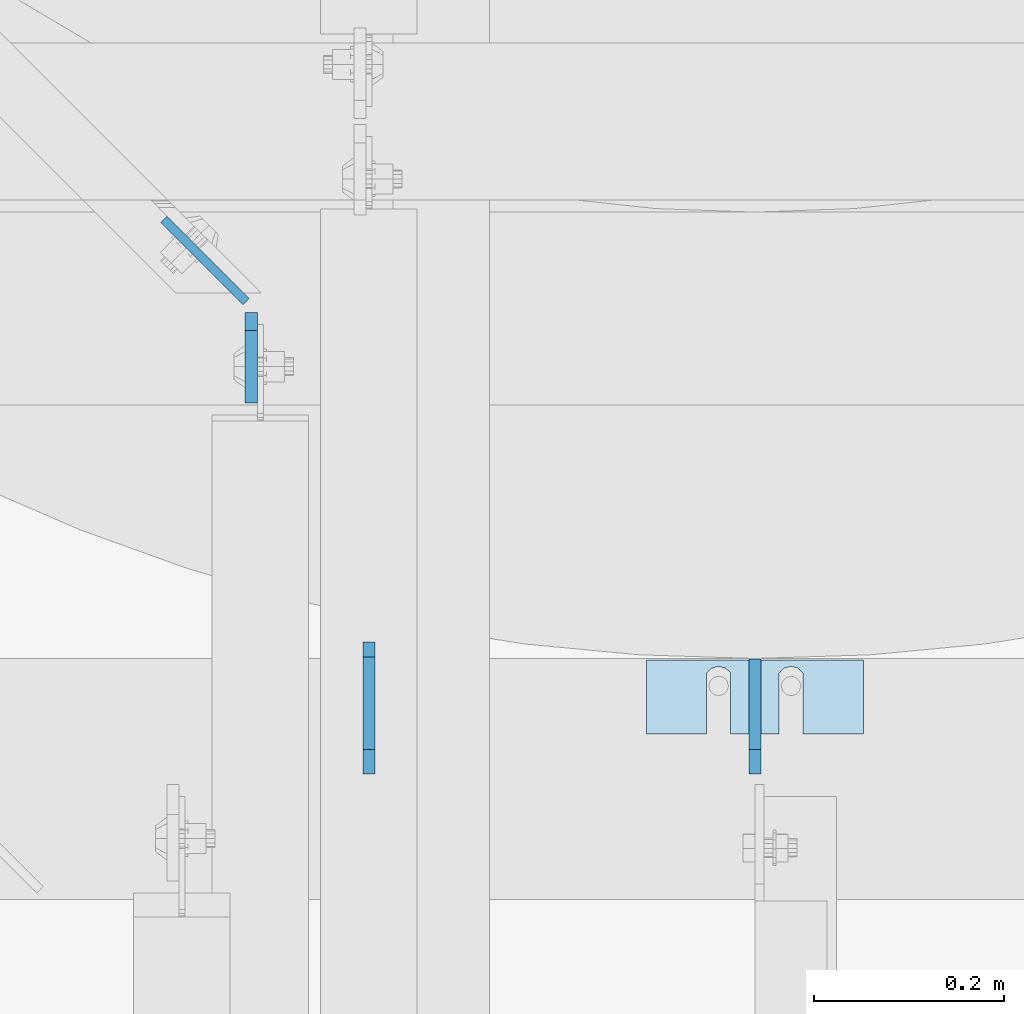
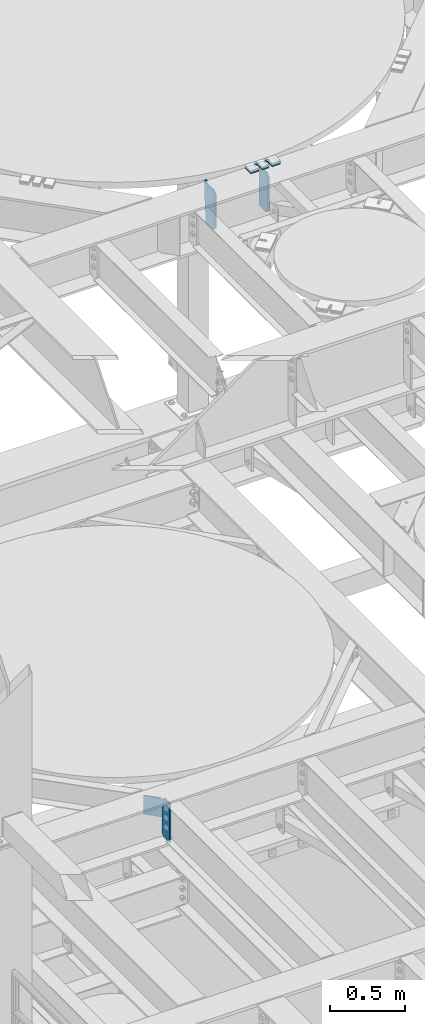
# One storey, part 1715 of 1876: 5 plates, 3 elements without a shape of their own.
"""IFC2X3 building model written with IfcOpenShell, lengths in millimetres."""

import ifcopenshell
import ifcopenshell.guid

model = None  # the IFC model being written
_history = None  # IfcOwnerHistory: only IFC2X3 demands one
_inside = {}  # id of a spatial element -> (the spatial element, [elements in it])
_under = {}  # id of a project, library or spatial element -> (it, [spatial elements below it])
_declared = {}  # id of a project -> (the project, [libraries it declares])
_typed = {}  # id of a type object -> (the type object, [elements of that type])
_made_of = {}  # id of a material, layer set ... -> (it, [elements and type objects made of it])


def new_model(schema):
    """Start an empty IFC model of exactly this schema.

    Asked for "IFC4X3", IfcOpenShell would pick the latest addendum, in which some entities
    have other attributes; the version numbers below select the first issue.
    IFC2X3 requires an IfcOwnerHistory on every rooted entity: one is made here for all.
    """
    global model, _history
    if schema == "IFC4X3":
        model = ifcopenshell.file(schema_version=(4, 3, 0, 0))
    else:
        model = ifcopenshell.file(schema=schema)
    _inside.clear()
    _under.clear()
    _declared.clear()
    _typed.clear()
    _made_of.clear()
    _history = None
    if model.schema == "IFC2X3":
        org = make("IfcOrganization", Name="unknown")
        user = make(
            "IfcPersonAndOrganization",
            ThePerson=make("IfcPerson", FamilyName="unknown"),
            TheOrganization=org,
        )
        app = make(
            "IfcApplication",
            ApplicationDeveloper=org,
            Version="unknown",
            ApplicationFullName="unknown",
            ApplicationIdentifier="unknown",
        )
        _history = make(
            "IfcOwnerHistory",
            OwningUser=user,
            OwningApplication=app,
            ChangeAction="ADDED",
            CreationDate=0,
        )
    return model


def make(cls, **values):
    """One entity of the class cls with the attributes given. An attribute that is None is left unset."""
    return model.create_entity(
        cls, **{name: value for name, value in values.items() if value is not None}
    )


def rooted(cls, **values):
    """An entity with a GlobalId (a new one), such as an element, a storey or a relation."""
    return make(cls, GlobalId=ifcopenshell.guid.new(), OwnerHistory=_history, **values)


def si_unit(unit_type, name, prefix=None):
    """IfcSIUnit, for example si_unit("LENGTHUNIT", "METRE", prefix="MILLI")."""
    return make("IfcSIUnit", UnitType=unit_type, Prefix=prefix, Name=name)


def assignment(units):
    """IfcUnitAssignment: the units of a project."""
    return None if units is None else make("IfcUnitAssignment", Units=units)


def point(xyz):
    """IfcCartesianPoint."""
    return None if xyz is None else make("IfcCartesianPoint", Coordinates=xyz)


def direction(xyz):
    """IfcDirection."""
    return None if xyz is None else make("IfcDirection", DirectionRatios=xyz)


def frame(location, z_axis=None, x_axis=None):
    """IfcAxis2Placement3D, a coordinate frame: its origin and axes. An axis left out is left unset."""
    return make(
        "IfcAxis2Placement3D",
        Location=point(location),
        Axis=direction(z_axis),
        RefDirection=direction(x_axis),
    )


def origin_with_axes():
    """The frame at (0, 0, 0) with the z axis (0, 0, 1) and the x axis (1, 0, 0) written out."""
    return frame((0.0, 0.0, 0.0), z_axis=(0.0, 0.0, 1.0), x_axis=(1.0, 0.0, 0.0))


def place(relative_to, where):
    """IfcLocalPlacement: puts the frame where relative to a parent placement (None: the world)."""
    return make(
        "IfcLocalPlacement", PlacementRelTo=relative_to, RelativePlacement=where
    )


def context(
    kind, dimensions, precision=None, world=None, true_north=None, identifier=None
):
    """IfcGeometricRepresentationContext, for example the 3D "Model" context."""
    return make(
        "IfcGeometricRepresentationContext",
        ContextIdentifier=identifier,
        ContextType=kind,
        CoordinateSpaceDimension=dimensions,
        Precision=precision,
        WorldCoordinateSystem=world,
        TrueNorth=true_north,
    )


def subcontext(parent, identifier, kind, view, scale=None):
    """IfcGeometricRepresentationSubContext, for example "Body" below "Model"."""
    return make(
        "IfcGeometricRepresentationSubContext",
        ContextIdentifier=identifier,
        ContextType=kind,
        ParentContext=parent,
        TargetScale=scale,
        TargetView=view,
    )


def project(units=None, contexts=None):
    """IfcProject with its units and contexts."""
    return rooted(
        "IfcProject",
        Name="project",
        RepresentationContexts=contexts,
        UnitsInContext=assignment(units),
    )


def spatial(cls, under=None, at=None, **own):
    """A site, building, storey or space (cls), placed at a placement, below another one or the project."""
    s = rooted(cls, ObjectPlacement=at, **own)
    if under is not None:
        _under.setdefault(under.id(), (under, []))[1].append(s)
    return s


def faces_of(points, faces, orient=None, outer=None):
    """IfcFace entities. A face is a list of loops; a loop is a list of indices into points, from 0.

    orient and outer hold one flag for each loop. By default every Orientation is true, the
    first loop of a face is its IfcFaceOuterBound and the others are IfcFaceBound.
    """
    made = []
    for i, loops in enumerate(faces):
        bounds = []
        for j, loop in enumerate(loops):
            is_outer = j == 0 if outer is None else outer[i][j]
            bounds.append(
                make(
                    "IfcFaceOuterBound" if is_outer else "IfcFaceBound",
                    Bound=make("IfcPolyLoop", Polygon=[points[k] for k in loop]),
                    Orientation=True if orient is None else orient[i][j],
                )
            )
        made.append(make("IfcFace", Bounds=bounds))
    return made


def faceted_brep(points, faces, orient=None, outer=None, voids=None):
    """IfcFacetedBrep: a solid bounded by flat faces; with voids (closed shells), ...WithVoids."""
    shared = [point(p) for p in points]
    hull = make("IfcClosedShell", CfsFaces=faces_of(shared, faces, orient, outer))
    if voids is None:
        return make("IfcFacetedBrep", Outer=hull)
    return make(
        "IfcFacetedBrepWithVoids",
        Outer=hull,
        Voids=[
            make(cls, CfsFaces=faces_of(shared, fs, o, b)) for cls, fs, o, b in voids
        ],
    )


def shape(context_of_items, identifier, shape_type, items):
    """IfcShapeRepresentation: the items that make up one representation, for example the "Body"."""
    return make(
        "IfcShapeRepresentation",
        ContextOfItems=context_of_items,
        RepresentationIdentifier=identifier,
        RepresentationType=shape_type,
        Items=items,
    )


def material(Name=None, Category=None):
    """IfcMaterial."""
    return make("IfcMaterial", Name=Name, Category=Category)


def made_of(thing, what):
    """Note that an element or type object is made of a material, layer set ...; save() writes the relation."""
    if what is not None:
        _made_of.setdefault(what.id(), (what, []))[1].append(thing)
    return thing


def type_object(cls, material=None, **own):
    """A type object (cls), such as IfcWallType, which elements share."""
    return made_of(rooted(cls, **own), material)


def element(
    cls,
    number,
    at=None,
    inside=None,
    cuts=None,
    type_object=None,
    material=None,
    context=None,
    identifier="Body",
    shape_type=None,
    held_by="IfcProductDefinitionShape",
    body=None,
    shapes=None,
    **own,
):
    """One element of the class cls, such as IfcWall. Its Tag is "e" and its number.

    at: its placement. inside: the storey or other place that contains it. cuts: it is an
    opening in that element (IfcRelVoidsElement). A single representation is given by context,
    identifier, shape_type and body (its items); several are given by shapes. held_by: the class
    of the entity that holds the representations. save() writes the other relations.
    """
    e = rooted(cls, Tag="e%d" % number, ObjectPlacement=at, **own)
    if body is not None:
        shapes = [shape(context, identifier, shape_type, body)]
    if shapes is not None:
        e.Representation = make(held_by, Representations=shapes)
    if inside is not None:
        _inside.setdefault(inside.id(), (inside, []))[1].append(e)
    if cuts is not None:
        rooted(
            "IfcRelVoidsElement", RelatingBuildingElement=cuts, RelatedOpeningElement=e
        )
    if type_object is not None:
        _typed.setdefault(type_object.id(), (type_object, []))[1].append(e)
    return made_of(e, material)


def aggregate(whole, parts):
    """IfcRelAggregates: a whole, such as a stair, and the parts it consists of."""
    return rooted("IfcRelAggregates", RelatingObject=whole, RelatedObjects=parts)


def save(model, path):
    """Write the relations noted so far, then the file.

    IfcRelAggregates (storeys below a building ...), IfcRelContainedInSpatialStructure (elements
    in a storey), IfcRelDefinesByType, IfcRelAssociatesMaterial and IfcRelDeclares: one each for
    every whole, place, type object, material and project.
    """
    for whole, parts in _under.values():
        aggregate(whole, parts)
    for where, things in _inside.values():
        rooted(
            "IfcRelContainedInSpatialStructure",
            RelatedElements=things,
            RelatingStructure=where,
        )
    for kind, things in _typed.values():
        rooted("IfcRelDefinesByType", RelatedObjects=things, RelatingType=kind)
    for what, things in _made_of.values():
        rooted("IfcRelAssociatesMaterial", RelatedObjects=things, RelatingMaterial=what)
    for by, libraries in _declared.values():
        rooted("IfcRelDeclares", RelatingContext=by, RelatedDefinitions=libraries)
    model.write(path)


model = new_model("IFC2X3")

# Units and contexts
model_context = context("Model", 3, precision=1e-05, world=origin_with_axes())
body_context = subcontext(model_context, "Body", "Model", "MODEL_VIEW")
ifc_project = project(units=[si_unit("LENGTHUNIT", "METRE", prefix="MILLI"), si_unit("AREAUNIT", "SQUARE_METRE"), si_unit("VOLUMEUNIT", "CUBIC_METRE"), si_unit("MASSUNIT", "GRAM", prefix="KILO"), si_unit("TIMEUNIT", "SECOND"), si_unit("PLANEANGLEUNIT", "RADIAN"), si_unit("SOLIDANGLEUNIT", "STERADIAN"), si_unit("THERMODYNAMICTEMPERATUREUNIT", "DEGREE_CELSIUS"), si_unit("LUMINOUSINTENSITYUNIT", "LUMEN")], contexts=[model_context])

# Site, building, storey
site_placement = place(None, origin_with_axes())
site = spatial("IfcSite", under=ifc_project, at=site_placement, CompositionType="ELEMENT")
building_placement = place(site_placement, origin_with_axes())
building = spatial("IfcBuilding", under=site, at=building_placement, Name="Undefined", CompositionType="ELEMENT")
storey_placement = place(building_placement, origin_with_axes())
storey = spatial("IfcBuildingStorey", under=building, at=storey_placement, Name="Undefined", CompositionType="ELEMENT", Elevation=0.0)

# Assembly, plate
assembly_1_placement = place(storey_placement, origin_with_axes())
assembly_1 = element("IfcElementAssembly", 1, at=assembly_1_placement, inside=storey, Name="BEAM", AssemblyPlace="NOTDEFINED", PredefinedType="RIGID_FRAME")
ifc_material = material(Name="STEEL/A36")
plate_type_1 = type_object("IfcPlateType", PredefinedType="NOTDEFINED")
plate_1_placement = place(assembly_1_placement, frame((2657.47499990463, 9914.73125, 7821.6125), z_axis=(0.0, 0.0, 1.0), x_axis=(0.0, -1.0, 0.0)))
plate_1 = element("IfcPlate", 2, at=plate_1_placement, type_object=plate_type_1, material=ifc_material, Name="PLATE", context=body_context, shape_type="Brep", body=[
    faceted_brep([(0.0, -6.35000000000196, 19.0499992370605), (-9.09494701772928e-13, -6.34999999999764, 296.862506866455), (1.81898940354586e-12, 6.34999999999786, 296.862506866455), (0.0, 6.35000000000105, 19.0499992370605), (19.0499992370587, -6.34999999999604, 315.912506103516), (19.0499992370624, 6.34999999999945, 315.912506103516), (95.25, -6.35000000000036, 315.912506103516), (95.25, 6.35000000000036, 315.912506103516), (95.25, -6.35000000000036, 0.0), (95.25, 6.35000000000036, 0.0), (19.0499992370642, -6.35000000000105, 0.0), (19.0499992370633, 6.35000000000105, 0.0)], [[[0, 1, 2, 3]], [[1, 4, 5, 2]], [[4, 6, 7, 5]], [[6, 8, 9, 7]], [[8, 10, 11, 9]], [[10, 0, 3, 11]], [[5, 7, 9, 11, 3, 2]], [[10, 8, 6, 4, 1, 0]]]),
])

assembly_2_placement = place(storey_placement, origin_with_axes())
assembly_2 = element("IfcElementAssembly", 3, at=assembly_2_placement, inside=storey, Name="SHIM PLATE", AssemblyPlace="NOTDEFINED", PredefinedType="RIGID_FRAME")
plate_type_2 = type_object("IfcPlateType", PredefinedType="NOTDEFINED")
plate_2_placement = place(assembly_2_placement, frame((3302.00186767578, 9470.66649261932, 13314.3625), z_axis=(-1.0, 0.0, 0.0), x_axis=(0.0, 1.0, 0.0)))
plate_2 = element("IfcPlate", 4, at=plate_2_placement, type_object=plate_type_2, material=ifc_material, Name="SHIM PLATE", context=body_context, shape_type="Brep", body=[
    faceted_brep([(-2.69435986410826e-07, -4.76250000000073, 88.9036802523951), (-2.69435986410826e-07, 4.76250000000073, 88.9036802523951), (64.2911367327433, 4.76250000000073, 88.9036792552824), (64.2911367327433, -4.76250000000073, 88.9036792552824), (69.5263870263134, 4.76250000000073, 83.4898931996322), (69.5263870263134, -4.76250000000073, 83.4898931996322), (64.2911372418766, -4.76250000000073, 63.5056518232714), (64.2911372418766, 4.76250000000073, 63.5056518232714), (-1.92456354852766e-07, 4.76250000000073, 63.5036806291737), (-1.92456354852766e-07, -4.76250000000073, 63.5036806291737), (69.5263873183958, -4.76250000000073, 68.9194380887884), (69.5263873183958, 4.76250000000073, 68.9194380887884), (71.4348903969494, -4.76250000000073, 76.2046656824641), (71.4348903969494, 4.76250000000073, 76.2046656824641), (64.2911372419694, -4.76250000000073, 139.705651823345), (64.2911372419694, 4.76250000000073, 139.705651823345), (-4.23391611548141e-07, 4.76250000000073, 139.703680607395), (-4.23391611548141e-07, -4.76250000000073, 139.703680607395), (69.5263873184886, -4.76250000000073, 145.119438088862), (69.5263873184886, 4.76250000000073, 145.119438088862), (71.434890397044, -4.76250000000073, 152.404665682537), (71.434890397044, 4.76250000000073, 152.404665682537), (69.5263870264062, -4.76250000000073, 159.689893199708), (69.5263870264062, 4.76250000000073, 159.689893199708), (64.2911367328361, -4.76250000000073, 165.103679255356), (64.2911367328361, 4.76250000000073, 165.103679255356), (-5.00371243106201e-07, -4.76250000000073, 165.103680230615), (-5.00371243106201e-07, 4.76250000000073, 165.103680230615), (-6.92813046043739e-07, -4.76250000000073, 228.601303100699), (-6.92813046043739e-07, 4.76250000000073, 228.601303100699), (78.1460113524699, -4.76250000000073, 228.601303100651), (78.1460113524699, 4.76250000000073, 228.601303100651), (78.1460113525918, -4.76250000000073, -4.72937244921923e-11), (78.1460113525918, 4.76250000000073, -4.72937244921923e-11), (0.0, -4.76249999999982, 0.0), (0.0, 4.76249999999982, 0.0)], [[[0, 1, 2, 3]], [[3, 2, 4, 5]], [[6, 7, 8, 9]], [[10, 11, 7, 6]], [[12, 13, 11, 10]], [[5, 4, 13, 12]], [[14, 15, 16, 17]], [[18, 19, 15, 14]], [[20, 21, 19, 18]], [[22, 23, 21, 20]], [[24, 25, 23, 22]], [[26, 27, 25, 24]], [[28, 29, 27, 26]], [[28, 30, 31, 29]], [[30, 32, 33, 31]], [[32, 34, 35, 33]], [[35, 34, 9, 8]], [[2, 1, 16, 15, 19, 21, 23, 25, 27, 29, 31, 33, 35, 8, 7, 11, 13, 4]], [[17, 16, 1, 0]], [[6, 9, 34, 32, 30, 28, 26, 24, 22, 20, 18, 14, 17, 0, 3, 5, 12, 10]]]),
])
aggregate(assembly_2, [plate_2])

# Plate
plate_type_3 = type_object("IfcPlateType", PredefinedType="NOTDEFINED")
plate_3_placement = place(assembly_1_placement, frame((2652.21667906833, 9926.03729391941, 8121.65), z_axis=(-0.707305809668415, 0.706907696668602, 0.0), x_axis=(0.0, 0.0, -1.0)))
plate_3 = element("IfcPlate", 5, at=plate_3_placement, type_object=plate_type_3, material=ifc_material, Name="PLATE", context=body_context, shape_type="Brep", body=[
    faceted_brep([(0.0, -4.76249999999982, 0.0), (0.0, -4.76250000000147, 122.735206604024), (0.0, 4.7625000000009, 122.735206604024), (0.0, 4.76249999999982, 0.0), (152.399993896484, -4.76250000000147, 122.735206604024), (152.399993896484, 4.7625000000009, 122.735206604024), (152.399993896484, -4.76249999999982, 0.0), (152.399993896484, 4.76249999999982, 0.0)], [[[0, 1, 2, 3]], [[1, 4, 5, 2]], [[4, 6, 7, 5]], [[6, 0, 3, 7]], [[5, 7, 3, 2]], [[6, 4, 1, 0]]]),
])

aggregate(assembly_1, [plate_3, plate_1])

# Assembly, plates
assembly_3_placement = place(storey_placement, origin_with_axes())
assembly_3 = element("IfcElementAssembly", 6, at=assembly_3_placement, inside=storey, Name="BEAM", AssemblyPlace="NOTDEFINED", PredefinedType="RIGID_FRAME")
plate_type_4 = type_object("IfcPlateType", PredefinedType="NOTDEFINED")
plate_4_placement = place(assembly_3_placement, frame((3187.7, 9428.95625, 12973.05), z_axis=(0.0, 0.0, 1.0), x_axis=(0.0, 1.0, 0.0)))
plate_4 = element("IfcPlate", 7, at=plate_4_placement, type_object=plate_type_4, material=ifc_material, Name="PLATE", context=body_context, shape_type="Brep", body=[
    faceted_brep([(0.0, -6.35000000000036, 25.4000000000005), (-1.13686837721616e-12, -6.35000000000082, 292.100006103516), (1.13686837721616e-12, 6.35000000000105, 292.100006103516), (0.0, 6.35000000000036, 25.4000000000005), (25.3999996185303, -6.34999999999991, 317.5), (25.3999996185303, 6.34999999999991, 317.5), (120.650001525899, -6.35000000000309, 317.5), (120.650001525897, 6.34999999999764, 317.5), (120.650001525899, -6.35000000000309, -1.81898940354586e-12), (120.650001525897, 6.34999999999764, -1.81898940354586e-12), (25.3999996185303, -6.34999999999991, 0.0), (25.3999996185303, 6.34999999999991, 0.0)], [[[0, 1, 2, 3]], [[1, 4, 5, 2]], [[4, 6, 7, 5]], [[6, 8, 9, 7]], [[8, 10, 11, 9]], [[10, 0, 3, 11]], [[5, 7, 9, 11, 3, 2]], [[10, 8, 6, 4, 1, 0]]]),
])
plate_type_5 = type_object("IfcPlateType", PredefinedType="NOTDEFINED")
plate_5_placement = place(assembly_3_placement, frame((2781.3, 9550.40050201416, 12973.05), z_axis=(0.0, 0.0, 1.0), x_axis=(0.0, -1.0, 0.0)))
plate_5 = element("IfcPlate", 8, at=plate_5_placement, type_object=plate_type_5, material=ifc_material, Name="PLATE", context=body_context, shape_type="Brep", body=[
    faceted_brep([(0.0, -6.35000000000036, 0.0), (-17.2371788024902, -6.34999999999991, 209.549987792969), (-17.2371788024902, 6.34999999999991, 209.549987792969), (0.0, 6.35000000000036, 0.0), (-17.2371788024902, -6.34999999999991, 336.549987792969), (-17.2371788024902, 6.34999999999991, 336.549987792969), (-1.58699798583984, -6.34999999999991, 336.549987792969), (-1.58699798583984, 6.34999999999991, 336.549987792969), (-1.58749866485596, -6.34999999999991, 317.499969482422), (-1.58749866485596, 6.34999999999991, 317.499969482422), (96.0442523956299, -6.34999999999991, 317.499993699623), (96.0442523956299, 6.34999999999991, 317.499993699623), (121.44425201416, -6.34999999999991, 292.10000038147), (121.44425201416, 6.34999999999991, 292.10000038147), (121.44425201416, -6.34999999999991, 25.3999996185303), (121.44425201416, 6.34999999999991, 25.3999996185303), (96.0442523956299, -6.34999999999991, 0.0), (96.0442523956299, 6.34999999999991, 0.0)], [[[0, 1, 2, 3]], [[1, 4, 5, 2]], [[4, 6, 7, 5]], [[6, 8, 9, 7]], [[8, 10, 11, 9]], [[10, 12, 13, 11]], [[12, 14, 15, 13]], [[14, 16, 17, 15]], [[16, 0, 3, 17]], [[5, 7, 9, 11, 13, 15, 17, 3, 2]], [[16, 14, 12, 10, 8, 6, 4, 1, 0]]]),
])
aggregate(assembly_3, [plate_4, plate_5])

save(model, "model.ifc")
